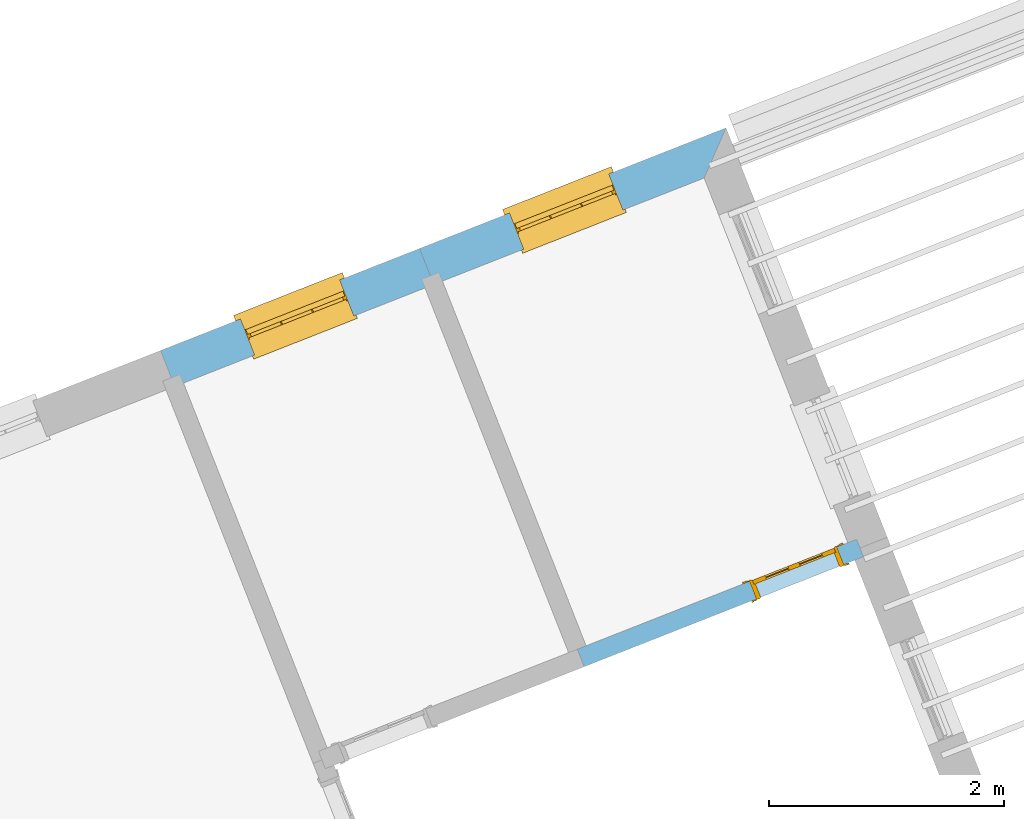
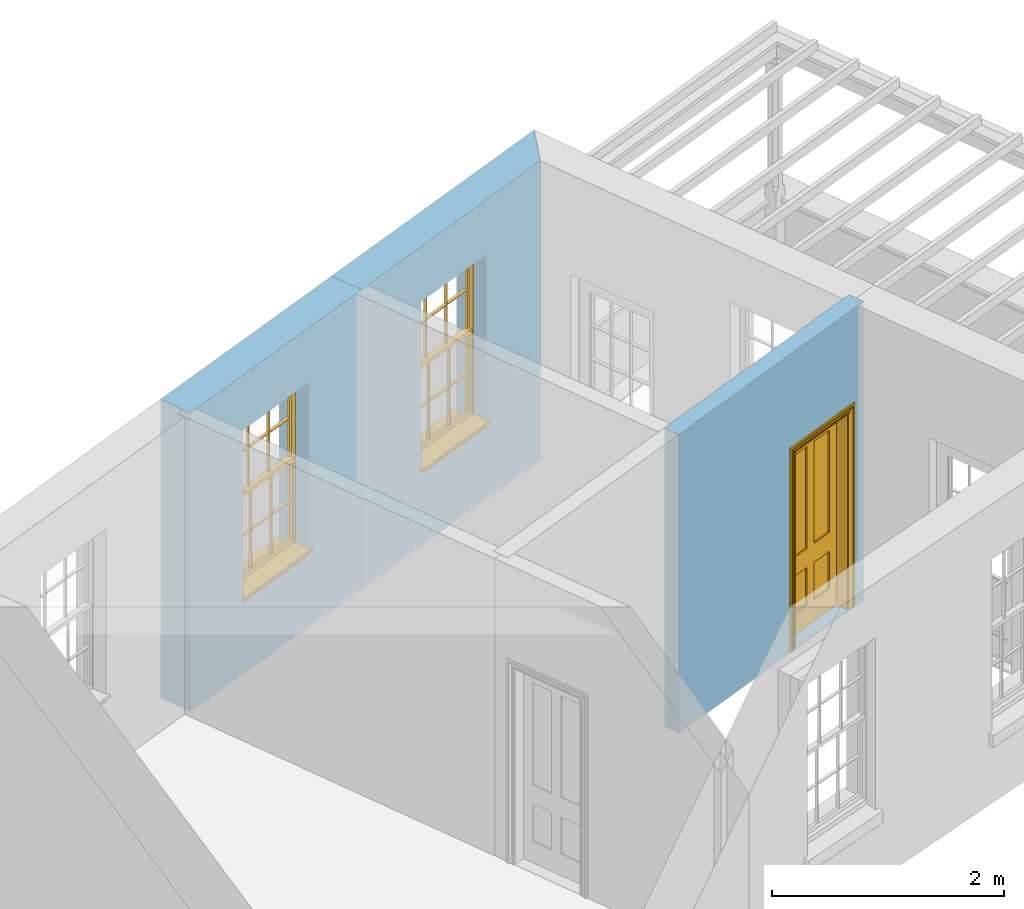
# One storey, part 4 of 8: 2 windows, 1 door, 3 openings, plus 3 elements that do not belong to this part.
"""IFC2X3 building model written with IfcOpenShell, lengths in metres."""

from ifc_helpers import new_model, si_unit, frame, origin, place, context, subcontext, project, spatial, polyline, outline, extrude, faceted_brep, material, layer, layer_set, layer_usage, element, fill, save


model = new_model("IFC2X3")

# Units and contexts
model_context = context("Model", 3, world=origin())
body_context = subcontext(model_context, "Body", "Model", "MODEL_VIEW")
ifc_project = project(units=[si_unit("PLANEANGLEUNIT", "RADIAN"), si_unit("MASSUNIT", "GRAM", prefix="KILO"), si_unit("FORCEUNIT", "NEWTON", prefix="KILO"), si_unit("LENGTHUNIT", "METRE")], contexts=[model_context])

# Site, building, storey
site_placement = place(None, origin())
site = spatial("IfcSite", under=ifc_project, at=site_placement, CompositionType="ELEMENT")
building_placement = place(None, origin())
building = spatial("IfcBuilding", under=site, at=building_placement, Name="Building plot-4", CompositionType="ELEMENT")
storey_placement = place(None, frame((0.0, 0.0, 9.45)))
storey = spatial("IfcBuildingStorey", under=building, at=storey_placement, Name="Floor 2", CompositionType="ELEMENT", Elevation=9.45)

# Wall, opening, window
ifc_material_1 = material(Name="Masonry")
ifc_layer_1 = layer(ifc_material_1, 0.33, ventilated=False)
ifc_layer_set_1 = layer_set([ifc_layer_1], Name="My Wall")
ifc_layer_usage_1 = layer_usage(ifc_layer_set_1, "AXIS2", "NEGATIVE", 0.08)
wall_1_placement = place(storey_placement, origin())
wall_1 = element("IfcWallStandardCase", 1, at=wall_1_placement, inside=storey, material=ifc_layer_usage_1, Name="exterior", context=body_context, shape_type="SweptSolid", body=[
    extrude(outline(polyline([(51.9622563685918, 53.743916100977), (52.148382249517, 54.1718847405405), (49.5373999145512, 53.1436274453256), (49.6583212938703, 52.8365801850812), (51.9622563685918, 53.743916100977)])), origin(), (0.0, 0.0, 1.0), 3.15),
])
opening_1_placement = place(storey_placement, frame((0.0, 0.0, 0.75)))
opening_1 = element("IfcOpeningElement", 2, at=opening_1_placement, cuts=wall_1, Name="Opening", ObjectType="Opening", context=body_context, shape_type="SweptSolid", body=[
    extrude(outline(polyline([(51.1499383422784, 53.7786774722522), (50.3032322609986, 53.4452276080691), (50.4241536403177, 53.1381803478247), (51.2708597215976, 53.4716302120078), (51.1499383422784, 53.7786774722522)])), origin(), (0.0, 0.0, 1.0), 1.82),
])
window_1_placement = place(storey_placement, frame((51.2415454478232, 53.546065911461, 0.75), z_axis=(0.0, 0.0, 1.0), x_axis=(-0.846706081279841, -0.333449864183102, 0.0)))
window_1 = element("IfcWindow", 3, at=window_1_placement, inside=storey, Name="bedroom outside window", OverallHeight=1.82, OverallWidth=0.91, context=body_context, shape_type="Brep", held_by="IfcProductRepresentation", body=[
    faceted_brep([(0.033125, -0.105, 0.975209), (0.01, -0.105, 0.975209), (0.033125, -0.105, 1.376042), (0.876875, -0.105, 0.975209), (0.876875, -0.105, 1.376042), (0.9, -0.105, 0.975209), (0.876875, -0.105, 1.386042), (0.876875, -0.105, 1.786875), (0.9, -0.105, 1.81), (0.033125, -0.105, 1.786875), (0.033125, -0.105, 1.386042), (0.01, -0.105, 1.81), (0.876875, -0.135, 1.376042), (0.876875, -0.135, 0.975209), (0.9, -0.135, 0.937083), (0.033125, -0.135, 1.786875), (0.01, -0.135, 1.81), (0.033125, -0.135, 1.386042), (0.01, -0.135, 0.937083), (0.033125, -0.135, 0.975209), (0.033125, -0.135, 1.376042), (0.876875, -0.135, 1.786875), (0.876875, -0.135, 1.386042), (0.9, -0.135, 1.81), (0.033125, -0.105, 0.937083), (0.01, -0.105, 0.937083), (0.033125, -0.105, 0.53625), (0.876875, -0.105, 0.937083), (0.876875, -0.105, 0.53625), (0.9, -0.105, 0.937083), (0.876875, -0.105, 0.52625), (0.876875, -0.105, 0.125417), (0.9, -0.105, 0.077167), (0.033125, -0.105, 0.125417), (0.033125, -0.105, 0.52625), (0.01, -0.105, 0.077167), (-0.0425, -0.25, 0.01), (-0.0425, -0.3, 0.001667), (0.0, -0.25, 0.01), (0.9525, -0.25, 0.01), (0.91, -0.25, 0.01), (0.9525, -0.3, 0.001667), (-0.02, 0.08, 0.077167), (0.0, 0.08, 0.077167), (-0.02, 0.11, 0.077167), (0.0, -0.06, 0.077167), (0.01, -0.06, 0.077167), (0.91, -0.06, 0.077167), (0.91, 0.08, 0.077167), (0.9, -0.06, 0.077167), (0.93, 0.08, 0.077167), (0.93, 0.11, 0.077167), (0.01, -0.075, 0.975209), (0.9, -0.075, 0.975209), (0.876875, -0.075, 0.125417), (0.876875, -0.075, 0.52625), (0.9, -0.075, 0.077167), (0.876875, -0.075, 0.53625), (0.876875, -0.075, 0.937083), (0.033125, -0.075, 0.125417), (0.01, -0.075, 0.077167), (0.033125, -0.075, 0.52625), (0.033125, -0.075, 0.937083), (0.033125, -0.075, 0.53625), (-0.02, 0.08, 0.052167), (-0.02, 0.11, 0.052167), (0.93, 0.11, 0.052167), (0.93, 0.08, 0.052167), (0.91, 0.08, 0.052167), (0.0, 0.08, 0.052167), (0.91, -0.15, 0.026667), (0.0, -0.15, 0.026667), (-0.0425, -0.3, -0.123333), (0.9525, -0.3, -0.123333), (-0.0425, -0.25, -0.123333), (0.9525, -0.25, -0.123333), (0.01, -0.06, 1.81), (0.9, -0.06, 1.81), (0.0, -0.06, 1.82), (0.91, -0.06, 1.82), (0.01, -0.15, 0.077167), (0.9, -0.15, 0.077167), (0.592292, -0.105, 0.125417), (0.592292, -0.075, 0.125417), (0.317708, -0.075, 0.125417), (0.317708, -0.105, 0.125417), (0.592292, -0.105, 0.53625), (0.317708, -0.105, 0.53625), (0.317708, -0.105, 0.52625), (0.592292, -0.105, 0.52625), (0.592292, -0.075, 0.53625), (0.317708, -0.075, 0.53625), (0.592292, -0.135, 1.386042), (0.592292, -0.105, 1.386042), (0.317708, -0.105, 1.386042), (0.317708, -0.135, 1.386042), (0.317708, -0.135, 1.376042), (0.592292, -0.135, 1.376042), (0.317708, -0.105, 1.376042), (0.592292, -0.105, 1.376042), (0.602292, -0.135, 1.376042), (0.592292, -0.135, 0.975209), (0.602292, -0.135, 0.975209), (0.602292, -0.105, 0.975209), (0.592292, -0.105, 0.975209), (0.602292, -0.105, 1.376042), (0.602292, -0.075, 0.53625), (0.602292, -0.105, 0.53625), (0.317708, -0.075, 0.52625), (0.307708, -0.075, 0.125417), (0.307708, -0.075, 0.52625), (0.602292, -0.075, 0.52625), (0.602292, -0.075, 0.125417), (0.592292, -0.075, 0.52625), (0.307708, -0.075, 0.53625), (0.317708, -0.075, 0.937083), (0.307708, -0.075, 0.937083), (0.602292, -0.075, 0.937083), (0.592292, -0.075, 0.937083), (0.307708, -0.105, 0.52625), (0.307708, -0.105, 0.125417), (0.307708, -0.105, 0.53625), (0.307708, -0.105, 0.937083), (0.592292, -0.105, 0.937083), (0.317708, -0.105, 0.937083), (0.602292, -0.105, 0.937083), (0.602292, -0.105, 0.52625), (0.602292, -0.105, 0.125417), (0.307708, -0.135, 1.386042), (0.307708, -0.135, 1.376042), (0.307708, -0.135, 0.975209), (0.317708, -0.135, 0.975209), (0.317708, -0.135, 1.786875), (0.307708, -0.135, 1.786875), (0.602292, -0.135, 1.786875), (0.592292, -0.135, 1.786875), (0.602292, -0.135, 1.386042), (0.602292, -0.105, 1.386042), (0.307708, -0.105, 1.386042), (0.307708, -0.105, 1.786875), (0.317708, -0.105, 1.786875), (0.592292, -0.105, 1.786875), (0.602292, -0.105, 1.786875), (0.307708, -0.105, 1.376042), (0.317708, -0.105, 0.975209), (0.307708, -0.105, 0.975209), (0.91, -0.15, 1.82), (0.9, -0.15, 1.81), (0.01, -0.15, 1.81), (0.0, -0.15, 1.82), (0.91, -0.25, 0.0), (0.0, -0.25, 0.0), (0.91, 0.08, 0.0), (0.0, 0.08, 0.0)], [[[0, 1, 2]], [[3, 4, 5]], [[6, 7, 8]], [[9, 10, 11]], [[12, 13, 14]], [[15, 16, 17]], [[18, 19, 20]], [[21, 22, 23]], [[24, 25, 26]], [[27, 28, 29]], [[30, 31, 32]], [[33, 34, 35]], [[14, 27, 29]], [[25, 24, 18]], [[36, 37, 38]], [[39, 40, 41]], [[42, 43, 44]], [[45, 46, 43]], [[47, 48, 49]], [[50, 51, 48]], [[1, 0, 52]], [[5, 53, 3]], [[54, 55, 56]], [[57, 58, 53]], [[59, 60, 61]], [[62, 63, 52]], [[48, 43, 46, 49]], [[51, 44, 43, 48]], [[64, 42, 44, 65]], [[65, 44, 51, 66]], [[66, 51, 50, 67]], [[65, 66, 68, 69]], [[60, 56, 49, 46]], [[70, 71, 38, 40]], [[37, 41, 40, 38]], [[37, 72, 73, 41]], [[74, 75, 73, 72]], [[8, 11, 76, 77]], [[76, 78, 79, 77]], [[32, 35, 80, 81]], [[81, 80, 71, 70]], [[82, 83, 84, 85]], [[86, 87, 88, 89]], [[86, 90, 91, 87]], [[92, 93, 94, 95]], [[92, 95, 96, 97]], [[96, 98, 99, 97]], [[100, 97, 101, 102]], [[103, 104, 99, 105]], [[97, 99, 104, 101]], [[102, 103, 105, 100]], [[28, 57, 106, 107]], [[108, 84, 109, 110]], [[111, 112, 83, 113]], [[114, 110, 61, 63]], [[90, 113, 108, 91]], [[115, 91, 114, 116]], [[117, 106, 90, 118]], [[111, 106, 57, 55]], [[119, 110, 109, 120]], [[34, 61, 110, 119]], [[89, 113, 83, 82]], [[88, 108, 113, 89]], [[85, 84, 108, 88]], [[121, 114, 63, 26]], [[122, 116, 114, 121]], [[123, 118, 90, 86]], [[87, 91, 115, 124]], [[107, 106, 117, 125]], [[126, 111, 55, 30]], [[127, 112, 111, 126]], [[126, 30, 28, 107]], [[88, 119, 120, 85]], [[126, 89, 82, 127]], [[125, 123, 86, 107]], [[121, 26, 34, 119]], [[124, 122, 121, 87]], [[128, 17, 20, 129]], [[96, 129, 130, 131]], [[132, 133, 128, 95]], [[134, 135, 92, 136]], [[100, 12, 22, 136]], [[137, 6, 4, 105]], [[94, 138, 139, 140]], [[137, 93, 141, 142]], [[99, 98, 94, 93]], [[143, 2, 10, 138]], [[144, 145, 143, 98]], [[129, 143, 145, 130]], [[20, 2, 143, 129]], [[131, 144, 98, 96]], [[128, 138, 10, 17]], [[133, 139, 138, 128]], [[135, 141, 93, 92]], [[95, 94, 140, 132]], [[22, 6, 137, 136]], [[136, 137, 142, 134]], [[100, 105, 4, 12]], [[107, 86, 89, 126]], [[106, 111, 113, 90]], [[91, 108, 110, 114]], [[87, 121, 119, 88]], [[97, 100, 136, 92]], [[129, 96, 95, 128]], [[98, 143, 138, 94]], [[105, 99, 93, 137]], [[131, 101, 104, 144]], [[124, 115, 118, 123]], [[132, 140, 141, 135]], [[120, 109, 59, 33]], [[15, 9, 139, 133]], [[134, 142, 7, 21]], [[31, 54, 112, 127]], [[36, 74, 72, 37]], [[39, 41, 73, 75]], [[18, 14, 101, 131]], [[23, 16, 132, 135]], [[83, 56, 60, 84]], [[52, 53, 118, 115]], [[53, 52, 144, 104]], [[11, 8, 141, 140]], [[14, 18, 124, 123]], [[2, 1, 11, 10]], [[8, 5, 4, 6]], [[57, 53, 56, 55]], [[60, 52, 63, 61]], [[26, 25, 35, 34]], [[32, 29, 28, 30]], [[14, 23, 22, 12]], [[18, 20, 17, 16]], [[19, 0, 2, 20]], [[17, 10, 9, 15]], [[12, 4, 3, 13]], [[21, 7, 6, 22]], [[27, 58, 57, 28]], [[30, 55, 54, 31]], [[33, 59, 61, 34]], [[26, 63, 62, 24]], [[5, 8, 77, 53]], [[76, 11, 1, 52]], [[46, 45, 78, 76]], [[49, 77, 79, 47]], [[70, 146, 147, 81]], [[71, 80, 148, 149]], [[19, 130, 145, 0]], [[102, 13, 3, 103]], [[116, 122, 24, 62]], [[29, 32, 81, 14]], [[80, 35, 25, 18]], [[60, 46, 76, 52]], [[77, 49, 56, 53]], [[23, 14, 81, 147]], [[16, 148, 80, 18]], [[35, 85, 120]], [[120, 33, 35]], [[127, 82, 32]], [[32, 31, 127]], [[32, 82, 85, 35]], [[102, 101, 14]], [[14, 13, 102]], [[18, 131, 130]], [[130, 19, 18]], [[134, 21, 23]], [[23, 135, 134]], [[16, 15, 133]], [[133, 132, 16]], [[11, 140, 139]], [[139, 9, 11]], [[142, 141, 8]], [[8, 7, 142]], [[23, 147, 148, 16]], [[146, 149, 148, 147]], [[52, 115, 116]], [[116, 62, 52]], [[118, 53, 117]], [[58, 117, 53]], [[27, 125, 117, 58]], [[56, 83, 112]], [[112, 54, 56]], [[109, 84, 60]], [[60, 59, 109]], [[125, 27, 14]], [[14, 123, 125]], [[122, 124, 18]], [[18, 24, 122]], [[145, 144, 52]], [[52, 0, 145]], [[103, 3, 53]], [[53, 104, 103]], [[79, 78, 149, 146]], [[78, 45, 71, 149]], [[146, 70, 47, 79]], [[150, 75, 74, 151]], [[68, 66, 67]], [[48, 68, 67, 50]], [[69, 64, 65]], [[42, 64, 69, 43]], [[69, 68, 152, 153]], [[70, 68, 48, 47]], [[150, 152, 68, 70]], [[43, 69, 71, 45]], [[69, 153, 151, 71]], [[152, 150, 151, 153]], [[38, 151, 74, 36]], [[71, 151, 38]], [[39, 75, 150, 40]], [[40, 150, 70]]]),
])
fill(opening_1, window_1)

wall_2_placement = place(storey_placement, origin())
wall_2 = element("IfcWallStandardCase", 4, at=wall_2_placement, inside=storey, material=ifc_layer_usage_1, Name="exterior", context=body_context, shape_type="SweptSolid", body=[
    extrude(outline(polyline([(49.6583212938703, 52.8365801850812), (49.5373999145512, 53.1436274453256), (47.3314871355126, 52.2748946786277), (47.4524085148317, 51.9678474183833), (49.6583212938703, 52.8365801850812)])), origin(), (0.0, 0.0, 1.0), 3.15),
])
opening_2_placement = place(storey_placement, frame((0.0, 0.0, 0.75)))
opening_2 = element("IfcOpeningElement", 5, at=opening_2_placement, cuts=wall_2, Name="Opening", ObjectType="Opening", context=body_context, shape_type="SweptSolid", body=[
    extrude(outline(polyline([(48.8577965656718, 52.8759859940682), (48.011090484392, 52.5425361298851), (48.1320118637111, 52.2354888696407), (48.978717944991, 52.5689387338238), (48.8577965656718, 52.8759859940682)])), origin(), (0.0, 0.0, 1.0), 1.82),
])
window_2_placement = place(storey_placement, frame((48.9494036712166, 52.643374433277, 0.75), z_axis=(0.0, 0.0, 1.0), x_axis=(-0.846706081279848, -0.333449864183095, 0.0)))
window_2 = element("IfcWindow", 6, at=window_2_placement, inside=storey, Name="toilet outside window", OverallHeight=1.82, OverallWidth=0.91, context=body_context, shape_type="Brep", held_by="IfcProductRepresentation", body=[
    faceted_brep([(0.033125, -0.105, 0.975209), (0.01, -0.105, 0.975209), (0.033125, -0.105, 1.376042), (0.876875, -0.105, 0.975209), (0.876875, -0.105, 1.376042), (0.9, -0.105, 0.975209), (0.876875, -0.105, 1.386042), (0.876875, -0.105, 1.786875), (0.9, -0.105, 1.81), (0.033125, -0.105, 1.786875), (0.033125, -0.105, 1.386042), (0.01, -0.105, 1.81), (0.876875, -0.135, 1.376042), (0.876875, -0.135, 0.975209), (0.9, -0.135, 0.937083), (0.033125, -0.135, 1.786875), (0.01, -0.135, 1.81), (0.033125, -0.135, 1.386042), (0.01, -0.135, 0.937083), (0.033125, -0.135, 0.975209), (0.033125, -0.135, 1.376042), (0.876875, -0.135, 1.786875), (0.876875, -0.135, 1.386042), (0.9, -0.135, 1.81), (0.033125, -0.105, 0.937083), (0.01, -0.105, 0.937083), (0.033125, -0.105, 0.53625), (0.876875, -0.105, 0.937083), (0.876875, -0.105, 0.53625), (0.9, -0.105, 0.937083), (0.876875, -0.105, 0.52625), (0.876875, -0.105, 0.125417), (0.9, -0.105, 0.077167), (0.033125, -0.105, 0.125417), (0.033125, -0.105, 0.52625), (0.01, -0.105, 0.077167), (-0.0425, -0.25, 0.01), (-0.0425, -0.3, 0.001667), (0.0, -0.25, 0.01), (0.9525, -0.25, 0.01), (0.91, -0.25, 0.01), (0.9525, -0.3, 0.001667), (-0.02, 0.08, 0.077167), (0.0, 0.08, 0.077167), (-0.02, 0.11, 0.077167), (0.0, -0.06, 0.077167), (0.01, -0.06, 0.077167), (0.91, -0.06, 0.077167), (0.91, 0.08, 0.077167), (0.9, -0.06, 0.077167), (0.93, 0.08, 0.077167), (0.93, 0.11, 0.077167), (0.01, -0.075, 0.975209), (0.9, -0.075, 0.975209), (0.876875, -0.075, 0.125417), (0.876875, -0.075, 0.52625), (0.9, -0.075, 0.077167), (0.876875, -0.075, 0.53625), (0.876875, -0.075, 0.937083), (0.033125, -0.075, 0.125417), (0.01, -0.075, 0.077167), (0.033125, -0.075, 0.52625), (0.033125, -0.075, 0.937083), (0.033125, -0.075, 0.53625), (-0.02, 0.08, 0.052167), (-0.02, 0.11, 0.052167), (0.93, 0.11, 0.052167), (0.93, 0.08, 0.052167), (0.91, 0.08, 0.052167), (0.0, 0.08, 0.052167), (0.91, -0.15, 0.026667), (0.0, -0.15, 0.026667), (-0.0425, -0.3, -0.123333), (0.9525, -0.3, -0.123333), (-0.0425, -0.25, -0.123333), (0.9525, -0.25, -0.123333), (0.01, -0.06, 1.81), (0.9, -0.06, 1.81), (0.0, -0.06, 1.82), (0.91, -0.06, 1.82), (0.01, -0.15, 0.077167), (0.9, -0.15, 0.077167), (0.592292, -0.105, 0.125417), (0.592292, -0.075, 0.125417), (0.317708, -0.075, 0.125417), (0.317708, -0.105, 0.125417), (0.592292, -0.105, 0.53625), (0.317708, -0.105, 0.53625), (0.317708, -0.105, 0.52625), (0.592292, -0.105, 0.52625), (0.592292, -0.075, 0.53625), (0.317708, -0.075, 0.53625), (0.592292, -0.135, 1.386042), (0.592292, -0.105, 1.386042), (0.317708, -0.105, 1.386042), (0.317708, -0.135, 1.386042), (0.317708, -0.135, 1.376042), (0.592292, -0.135, 1.376042), (0.317708, -0.105, 1.376042), (0.592292, -0.105, 1.376042), (0.602292, -0.135, 1.376042), (0.592292, -0.135, 0.975209), (0.602292, -0.135, 0.975209), (0.602292, -0.105, 0.975209), (0.592292, -0.105, 0.975209), (0.602292, -0.105, 1.376042), (0.602292, -0.075, 0.53625), (0.602292, -0.105, 0.53625), (0.317708, -0.075, 0.52625), (0.307708, -0.075, 0.125417), (0.307708, -0.075, 0.52625), (0.602292, -0.075, 0.52625), (0.602292, -0.075, 0.125417), (0.592292, -0.075, 0.52625), (0.307708, -0.075, 0.53625), (0.317708, -0.075, 0.937083), (0.307708, -0.075, 0.937083), (0.602292, -0.075, 0.937083), (0.592292, -0.075, 0.937083), (0.307708, -0.105, 0.52625), (0.307708, -0.105, 0.125417), (0.307708, -0.105, 0.53625), (0.307708, -0.105, 0.937083), (0.592292, -0.105, 0.937083), (0.317708, -0.105, 0.937083), (0.602292, -0.105, 0.937083), (0.602292, -0.105, 0.52625), (0.602292, -0.105, 0.125417), (0.307708, -0.135, 1.386042), (0.307708, -0.135, 1.376042), (0.307708, -0.135, 0.975209), (0.317708, -0.135, 0.975209), (0.317708, -0.135, 1.786875), (0.307708, -0.135, 1.786875), (0.602292, -0.135, 1.786875), (0.592292, -0.135, 1.786875), (0.602292, -0.135, 1.386042), (0.602292, -0.105, 1.386042), (0.307708, -0.105, 1.386042), (0.307708, -0.105, 1.786875), (0.317708, -0.105, 1.786875), (0.592292, -0.105, 1.786875), (0.602292, -0.105, 1.786875), (0.307708, -0.105, 1.376042), (0.317708, -0.105, 0.975209), (0.307708, -0.105, 0.975209), (0.91, -0.15, 1.82), (0.9, -0.15, 1.81), (0.01, -0.15, 1.81), (0.0, -0.15, 1.82), (0.91, -0.25, 0.0), (0.0, -0.25, 0.0), (0.91, 0.08, 0.0), (0.0, 0.08, 0.0)], [[[0, 1, 2]], [[3, 4, 5]], [[6, 7, 8]], [[9, 10, 11]], [[12, 13, 14]], [[15, 16, 17]], [[18, 19, 20]], [[21, 22, 23]], [[24, 25, 26]], [[27, 28, 29]], [[30, 31, 32]], [[33, 34, 35]], [[14, 27, 29]], [[25, 24, 18]], [[36, 37, 38]], [[39, 40, 41]], [[42, 43, 44]], [[45, 46, 43]], [[47, 48, 49]], [[50, 51, 48]], [[1, 0, 52]], [[5, 53, 3]], [[54, 55, 56]], [[57, 58, 53]], [[59, 60, 61]], [[62, 63, 52]], [[48, 43, 46, 49]], [[51, 44, 43, 48]], [[64, 42, 44, 65]], [[65, 44, 51, 66]], [[66, 51, 50, 67]], [[65, 66, 68, 69]], [[60, 56, 49, 46]], [[70, 71, 38, 40]], [[37, 41, 40, 38]], [[37, 72, 73, 41]], [[74, 75, 73, 72]], [[8, 11, 76, 77]], [[76, 78, 79, 77]], [[32, 35, 80, 81]], [[81, 80, 71, 70]], [[82, 83, 84, 85]], [[86, 87, 88, 89]], [[86, 90, 91, 87]], [[92, 93, 94, 95]], [[92, 95, 96, 97]], [[96, 98, 99, 97]], [[100, 97, 101, 102]], [[103, 104, 99, 105]], [[97, 99, 104, 101]], [[102, 103, 105, 100]], [[28, 57, 106, 107]], [[108, 84, 109, 110]], [[111, 112, 83, 113]], [[114, 110, 61, 63]], [[90, 113, 108, 91]], [[115, 91, 114, 116]], [[117, 106, 90, 118]], [[111, 106, 57, 55]], [[119, 110, 109, 120]], [[34, 61, 110, 119]], [[89, 113, 83, 82]], [[88, 108, 113, 89]], [[85, 84, 108, 88]], [[121, 114, 63, 26]], [[122, 116, 114, 121]], [[123, 118, 90, 86]], [[87, 91, 115, 124]], [[107, 106, 117, 125]], [[126, 111, 55, 30]], [[127, 112, 111, 126]], [[126, 30, 28, 107]], [[88, 119, 120, 85]], [[126, 89, 82, 127]], [[125, 123, 86, 107]], [[121, 26, 34, 119]], [[124, 122, 121, 87]], [[128, 17, 20, 129]], [[96, 129, 130, 131]], [[132, 133, 128, 95]], [[134, 135, 92, 136]], [[100, 12, 22, 136]], [[137, 6, 4, 105]], [[94, 138, 139, 140]], [[137, 93, 141, 142]], [[99, 98, 94, 93]], [[143, 2, 10, 138]], [[144, 145, 143, 98]], [[129, 143, 145, 130]], [[20, 2, 143, 129]], [[131, 144, 98, 96]], [[128, 138, 10, 17]], [[133, 139, 138, 128]], [[135, 141, 93, 92]], [[95, 94, 140, 132]], [[22, 6, 137, 136]], [[136, 137, 142, 134]], [[100, 105, 4, 12]], [[107, 86, 89, 126]], [[106, 111, 113, 90]], [[91, 108, 110, 114]], [[87, 121, 119, 88]], [[97, 100, 136, 92]], [[129, 96, 95, 128]], [[98, 143, 138, 94]], [[105, 99, 93, 137]], [[131, 101, 104, 144]], [[124, 115, 118, 123]], [[132, 140, 141, 135]], [[120, 109, 59, 33]], [[15, 9, 139, 133]], [[134, 142, 7, 21]], [[31, 54, 112, 127]], [[36, 74, 72, 37]], [[39, 41, 73, 75]], [[18, 14, 101, 131]], [[23, 16, 132, 135]], [[83, 56, 60, 84]], [[52, 53, 118, 115]], [[53, 52, 144, 104]], [[11, 8, 141, 140]], [[14, 18, 124, 123]], [[2, 1, 11, 10]], [[8, 5, 4, 6]], [[57, 53, 56, 55]], [[60, 52, 63, 61]], [[26, 25, 35, 34]], [[32, 29, 28, 30]], [[14, 23, 22, 12]], [[18, 20, 17, 16]], [[19, 0, 2, 20]], [[17, 10, 9, 15]], [[12, 4, 3, 13]], [[21, 7, 6, 22]], [[27, 58, 57, 28]], [[30, 55, 54, 31]], [[33, 59, 61, 34]], [[26, 63, 62, 24]], [[5, 8, 77, 53]], [[76, 11, 1, 52]], [[46, 45, 78, 76]], [[49, 77, 79, 47]], [[70, 146, 147, 81]], [[71, 80, 148, 149]], [[19, 130, 145, 0]], [[102, 13, 3, 103]], [[116, 122, 24, 62]], [[29, 32, 81, 14]], [[80, 35, 25, 18]], [[60, 46, 76, 52]], [[77, 49, 56, 53]], [[23, 14, 81, 147]], [[16, 148, 80, 18]], [[35, 85, 120]], [[120, 33, 35]], [[127, 82, 32]], [[32, 31, 127]], [[32, 82, 85, 35]], [[102, 101, 14]], [[14, 13, 102]], [[18, 131, 130]], [[130, 19, 18]], [[134, 21, 23]], [[23, 135, 134]], [[16, 15, 133]], [[133, 132, 16]], [[11, 140, 139]], [[139, 9, 11]], [[142, 141, 8]], [[8, 7, 142]], [[23, 147, 148, 16]], [[146, 149, 148, 147]], [[52, 115, 116]], [[116, 62, 52]], [[118, 53, 117]], [[58, 117, 53]], [[27, 125, 117, 58]], [[56, 83, 112]], [[112, 54, 56]], [[109, 84, 60]], [[60, 59, 109]], [[125, 27, 14]], [[14, 123, 125]], [[122, 124, 18]], [[18, 24, 122]], [[145, 144, 52]], [[52, 0, 145]], [[103, 3, 53]], [[53, 104, 103]], [[79, 78, 149, 146]], [[78, 45, 71, 149]], [[146, 70, 47, 79]], [[150, 75, 74, 151]], [[68, 66, 67]], [[48, 68, 67, 50]], [[69, 64, 65]], [[42, 64, 69, 43]], [[69, 68, 152, 153]], [[70, 68, 48, 47]], [[150, 152, 68, 70]], [[43, 69, 71, 45]], [[69, 153, 151, 71]], [[152, 150, 151, 153]], [[38, 151, 74, 36]], [[71, 151, 38]], [[39, 75, 150, 40]], [[40, 150, 70]]]),
])
fill(opening_2, window_2)

# Wall, opening, door
ifc_material_2 = material(Name="Masonry")
ifc_layer_2 = layer(ifc_material_2, 0.16, ventilated=False)
ifc_layer_set_2 = layer_set([ifc_layer_2], Name="My Wall")
ifc_layer_usage_2 = layer_usage(ifc_layer_set_2, "AXIS2", "NEGATIVE", 0.08)
wall_3_placement = place(storey_placement, origin())
wall_3 = element("IfcWallStandardCase", 7, at=wall_3_placement, inside=storey, material=ifc_layer_usage_2, Name="interior", context=body_context, shape_type="SweptSolid", body=[
    extrude(outline(polyline([(50.8818764388166, 49.7296915841659), (50.9405049863652, 49.5808201852595), (53.3188757605398, 50.5174703749296), (53.2602472129912, 50.666341773836), (50.8818764388166, 49.7296915841659)])), origin(), (0.0, 0.0, 1.0), 3.15),
])
opening_3_placement = place(storey_placement, frame((0.0, 0.0, 0.0199999999999996)))
opening_3 = element("IfcOpeningElement", 8, at=opening_3_placement, cuts=wall_3, Name="Opening", ObjectType="Opening", context=body_context, shape_type="SweptSolid", body=[
    extrude(outline(polyline([(52.4070384422385, 50.158370521194), (53.1513954367702, 50.4515132589374), (53.0927668892215, 50.6003846578437), (52.3484098946898, 50.3072419201003), (52.4070384422385, 50.158370521194)])), origin(), (0.0, 0.0, 1.0), 2.1),
])
door_placement = place(storey_placement, frame((52.3777241684641, 50.2328062206471, 0.0199999999999996), z_axis=(0.0, 0.0, 1.0), x_axis=(0.744356994531735, 0.293142737743388, 0.0)))
door = element("IfcDoor", 9, at=door_placement, inside=storey, Name="bedroom inside door", OverallHeight=2.1, OverallWidth=0.8, context=body_context, shape_type="Brep", held_by="IfcProductRepresentation", body=[
    faceted_brep([(0.773, 0.08, 1.895), (0.66, 0.08, 1.895), (0.66, 0.08, 2.073), (0.773, 0.08, 2.073), (0.773, 0.08, 0.82), (0.66, 0.08, 0.82), (0.45, 0.08, 1.895), (0.45, 0.08, 2.073), (0.773, 0.08, 0.62), (0.66, 0.08, 0.62), (0.66, 0.065, 0.82), (0.66, 0.065, 1.895), (0.45, 0.065, 1.895), (0.35, 0.08, 1.895), (0.35, 0.08, 2.073), (0.773, 0.08, 0.225), (0.66, 0.08, 0.225), (0.45, 0.08, 0.62), (0.45, 0.08, 0.82), (0.45, 0.065, 0.82), (0.35, 0.08, 0.82), (0.14, 0.08, 2.073), (0.14, 0.08, 1.895), (0.773, 0.08, 0.0), (0.66, 0.08, 0.0), (0.66, 0.065, 0.225), (0.66, 0.065, 0.62), (0.45, 0.065, 0.62), (0.35, 0.08, 0.62), (0.35, 0.065, 0.82), (0.35, 0.065, 1.895), (0.14, 0.065, 1.895), (0.027, 0.08, 2.073), (0.027, 0.08, 1.895), (0.773, 0.042, 0.0), (0.66, 0.042, 0.0), (0.45, 0.08, 0.0), (0.45, 0.08, 0.225), (0.45, 0.065, 0.225), (0.35, 0.08, 0.225), (0.14, 0.08, 0.82), (0.14, 0.08, 0.62), (0.14, 0.065, 0.82), (0.027, 0.08, 0.82), (0.773, 0.042, 0.225), (0.66, 0.042, 0.225), (0.45, 0.042, 0.0), (0.35, 0.08, 0.0), (0.35, 0.065, 0.225), (0.35, 0.065, 0.62), (0.14, 0.065, 0.62), (0.027, 0.08, 0.62), (0.773, 0.042, 0.62), (0.66, 0.042, 0.62), (0.45, 0.042, 0.225), (0.35, 0.042, 0.0), (0.14, 0.08, 0.225), (0.14, 0.08, 0.0), (0.14, 0.065, 0.225), (0.027, 0.08, 0.225), (0.773, 0.042, 0.82), (0.66, 0.042, 0.82), (0.66, 0.057, 0.62), (0.66, 0.057, 0.225), (0.45, 0.057, 0.225), (0.35, 0.042, 0.225), (0.14, 0.042, 0.0), (0.027, 0.08, 0.0), (0.773, 0.042, 1.895), (0.66, 0.042, 1.895), (0.45, 0.042, 0.62), (0.45, 0.042, 0.82), (0.45, 0.057, 0.62), (0.35, 0.042, 0.62), (0.14, 0.042, 0.225), (0.027, 0.042, 0.0), (0.773, 0.042, 2.073), (0.66, 0.042, 2.073), (0.66, 0.057, 1.895), (0.66, 0.057, 0.82), (0.45, 0.057, 0.82), (0.35, 0.042, 0.82), (0.35, 0.057, 0.62), (0.35, 0.057, 0.225), (0.14, 0.057, 0.225), (0.027, 0.042, 0.225), (0.45, 0.042, 1.895), (0.45, 0.042, 2.073), (0.45, 0.057, 1.895), (0.35, 0.042, 1.895), (0.14, 0.042, 0.82), (0.14, 0.042, 0.62), (0.14, 0.057, 0.62), (0.027, 0.042, 0.62), (0.35, 0.042, 2.073), (0.35, 0.057, 1.895), (0.35, 0.057, 0.82), (0.14, 0.057, 0.82), (0.027, 0.042, 0.82), (0.14, 0.042, 2.073), (0.14, 0.042, 1.895), (0.14, 0.057, 1.895), (0.027, 0.042, 1.895), (0.027, 0.042, 2.073), (0.02, 0.085, 0.0), (0.005, 0.09, 0.0), (0.005, 0.09, 2.095), (0.02, 0.085, 2.08), (0.02, 0.08, 0.0), (0.0, 0.085, 0.0), (0.0, 0.085, 2.1), (0.795, 0.09, 2.095), (0.78, 0.085, 2.08), (0.02, 0.08, 2.08), (0.0, 0.08, 0.0), (-0.032, 0.095, 0.0), (-0.032, 0.095, 2.132), (0.8, 0.085, 2.1), (0.795, 0.09, 0.0), (0.78, 0.085, 0.0), (0.78, 0.08, 2.08), (0.04, 0.04, 0.0), (0.025, 0.04, 0.0), (0.025, 0.04, 2.075), (0.04, 0.04, 2.06), (-0.04, 0.09, 0.0), (-0.04, 0.09, 2.14), (0.832, 0.095, 2.132), (0.8, 0.085, 0.0), (0.78, 0.08, 0.0), (0.8, 0.08, 0.0), (0.86, 0.08, 0.0), (0.86, 0.08, 2.16), (0.8, 0.08, 2.1), (-0.06, 0.08, 2.16), (0.0, 0.08, 2.1), (-0.06, 0.08, 0.0), (-0.04, 0.095, 0.0), (-0.04, 0.095, 2.14), (0.84, 0.09, 2.14), (0.832, 0.095, 0.0), (0.84, 0.09, 0.0), (0.86, 0.095, 0.0), (0.86, 0.095, 2.16), (-0.06, 0.095, 2.16), (-0.06, 0.095, 0.0), (0.84, 0.095, 0.0), (0.84, 0.095, 2.14), (-0.025, -0.095, 0.0), (-0.025, -0.09, 0.0), (-0.025, -0.09, 2.125), (-0.025, -0.095, 2.125), (-0.017, -0.095, 0.0), (-0.017, -0.095, 2.117), (0.825, -0.09, 2.125), (0.825, -0.095, 2.125), (0.825, -0.095, 0.0), (0.845, -0.095, 0.0), (-0.045, -0.095, 2.145), (-0.045, -0.095, 0.0), (0.845, -0.095, 2.145), (0.015, -0.085, 0.0), (0.015, -0.085, 2.085), (0.817, -0.095, 2.117), (0.825, -0.09, 0.0), (0.845, -0.08, 0.0), (0.845, -0.08, 2.145), (-0.045, -0.08, 2.145), (-0.045, -0.08, 0.0), (0.02, -0.09, 0.0), (0.02, -0.09, 2.08), (0.785, -0.085, 2.085), (0.817, -0.095, 0.0), (0.8, -0.08, 0.0), (0.8, -0.08, 2.1), (0.0, -0.08, 2.1), (0.0, -0.08, 0.0), (0.035, -0.085, 0.0), (0.035, -0.085, 2.065), (0.78, -0.09, 2.08), (0.785, -0.085, 0.0), (0.775, 0.04, 2.075), (0.76, 0.04, 2.06), (0.035, -0.08, 2.065), (0.035, -0.08, 0.0), (0.765, -0.085, 2.065), (0.78, -0.09, 0.0), (0.765, -0.08, 0.0), (0.765, -0.08, 2.065), (0.765, -0.085, 0.0), (0.04, -0.08, 2.06), (0.04, -0.08, 0.0), (0.76, -0.08, 2.06), (0.76, -0.08, 0.0), (0.76, 0.04, 0.0), (0.775, 0.04, 0.0), (0.025, 0.08, 0.0), (0.025, 0.08, 2.075), (0.775, 0.08, 0.0), (0.775, 0.08, 2.075)], [[[0, 1, 2, 3]], [[1, 0, 4, 5]], [[1, 6, 7, 2]], [[8, 9, 5, 4]], [[1, 5, 10, 11]], [[6, 1, 11, 12]], [[6, 13, 14, 7]], [[15, 16, 9, 8]], [[9, 17, 18, 5]], [[5, 18, 19, 10]], [[10, 19, 12, 11]], [[18, 6, 12, 19]], [[18, 20, 13, 6]], [[21, 14, 13, 22]], [[23, 24, 16, 15]], [[9, 16, 25, 26]], [[17, 9, 26, 27]], [[17, 28, 20, 18]], [[13, 20, 29, 30]], [[22, 13, 30, 31]], [[32, 21, 22, 33]], [[34, 35, 24, 23]], [[24, 36, 37, 16]], [[16, 37, 38, 25]], [[25, 38, 27, 26]], [[37, 17, 27, 38]], [[37, 39, 28, 17]], [[40, 20, 28, 41]], [[20, 40, 42, 29]], [[31, 30, 29, 42]], [[40, 22, 31, 42]], [[33, 22, 40, 43]], [[35, 34, 44, 45]], [[35, 46, 36, 24]], [[36, 47, 39, 37]], [[28, 39, 48, 49]], [[41, 28, 49, 50]], [[43, 40, 41, 51]], [[45, 44, 52, 53]], [[46, 35, 45, 54]], [[46, 55, 47, 36]], [[56, 39, 47, 57]], [[39, 56, 58, 48]], [[50, 49, 48, 58]], [[56, 41, 50, 58]], [[51, 41, 56, 59]], [[53, 52, 60, 61]], [[45, 53, 62, 63]], [[54, 45, 63, 64]], [[55, 46, 54, 65]], [[55, 66, 57, 47]], [[59, 56, 57, 67]], [[61, 60, 68, 69]], [[70, 53, 61, 71]], [[53, 70, 72, 62]], [[72, 64, 63, 62]], [[70, 54, 64, 72]], [[65, 54, 70, 73]], [[65, 74, 66, 55]], [[67, 57, 66, 75]], [[69, 68, 76, 77]], [[61, 69, 78, 79]], [[71, 61, 79, 80]], [[73, 70, 71, 81]], [[65, 73, 82, 83]], [[74, 65, 83, 84]], [[74, 85, 75, 66]], [[86, 69, 77, 87]], [[69, 86, 88, 78]], [[88, 80, 79, 78]], [[86, 71, 80, 88]], [[81, 71, 86, 89]], [[73, 81, 90, 91]], [[73, 91, 92, 82]], [[83, 82, 92, 84]], [[91, 74, 84, 92]], [[91, 93, 85, 74]], [[89, 86, 87, 94]], [[81, 89, 95, 96]], [[90, 81, 96, 97]], [[90, 98, 93, 91]], [[94, 99, 100, 89]], [[89, 100, 101, 95]], [[101, 97, 96, 95]], [[100, 90, 97, 101]], [[100, 102, 98, 90]], [[99, 103, 102, 100]], [[32, 103, 99, 21]], [[102, 103, 32, 33]], [[98, 102, 33, 43]], [[21, 99, 94, 14]], [[94, 87, 7, 14]], [[7, 87, 77, 2]], [[76, 3, 2, 77]], [[43, 51, 93, 98]], [[51, 59, 85, 93]], [[67, 75, 85, 59]], [[34, 23, 15, 44]], [[44, 15, 8, 52]], [[52, 8, 4, 60]], [[0, 68, 60, 4]], [[0, 3, 76, 68]], [[104, 105, 106, 107]], [[104, 108, 109, 105]], [[105, 109, 110, 106]], [[107, 106, 111, 112]], [[107, 113, 108, 104]], [[114, 109, 108]], [[109, 115, 116, 110]], [[106, 110, 117, 111]], [[112, 111, 118, 119]], [[113, 107, 112, 120]], [[121, 122, 123, 124]], [[115, 109, 114, 125]], [[115, 125, 126, 116]], [[110, 116, 127, 117]], [[111, 117, 128, 118]], [[118, 128, 129, 119]], [[120, 112, 119, 129]], [[130, 129, 128]], [[130, 131, 132, 133]], [[133, 132, 134, 135]], [[135, 134, 136, 114]], [[136, 125, 114]], [[125, 137, 138, 126]], [[116, 126, 139, 127]], [[117, 127, 140, 128]], [[141, 130, 128, 140]], [[131, 130, 141]], [[131, 142, 143, 132]], [[132, 143, 144, 134]], [[134, 144, 145, 136]], [[137, 125, 136, 145]], [[143, 142, 146]], [[143, 146, 147]], [[137, 145, 144]], [[143, 147, 138]], [[138, 137, 144]], [[143, 138, 144]], [[126, 138, 147, 139]], [[127, 139, 141, 140]], [[142, 131, 141, 146]], [[139, 147, 146, 141]], [[148, 149, 150, 151]], [[149, 152, 153, 150]], [[151, 150, 154, 155]], [[155, 156, 157]], [[158, 159, 148]], [[158, 148, 151]], [[155, 157, 160]], [[158, 151, 155]], [[155, 160, 158]], [[152, 161, 162, 153]], [[150, 153, 163, 154]], [[155, 154, 164, 156]], [[156, 164, 165, 157]], [[157, 165, 166, 160]], [[160, 166, 167, 158]], [[158, 167, 168, 159]], [[161, 169, 170, 162]], [[153, 162, 171, 163]], [[154, 163, 172, 164]], [[165, 164, 173]], [[165, 173, 174, 166]], [[166, 174, 175, 167]], [[167, 175, 176, 168]], [[169, 177, 178, 170]], [[162, 170, 179, 171]], [[163, 171, 180, 172]], [[172, 180, 173, 164]], [[124, 123, 181, 182]], [[183, 178, 177, 184]], [[170, 178, 185, 179]], [[171, 179, 186, 180]], [[187, 173, 180]], [[185, 188, 187, 189]], [[188, 185, 178, 183]], [[179, 185, 189, 186]], [[189, 187, 180, 186]], [[190, 183, 184, 191]], [[192, 188, 183, 190]], [[191, 184, 122, 121]], [[124, 190, 191, 121]], [[193, 187, 188, 192]], [[182, 192, 190, 124]], [[184, 176, 122]], [[194, 195, 187, 193]], [[192, 182, 194, 193]], [[161, 176, 184]], [[114, 108, 122, 176]], [[173, 187, 195]], [[152, 149, 176, 161]], [[169, 161, 184, 177]], [[196, 122, 108]], [[176, 175, 135, 114]], [[173, 195, 129, 130]], [[176, 149, 168]], [[123, 122, 196, 197]], [[196, 108, 113, 197]], [[175, 174, 133, 135]], [[198, 129, 195]], [[133, 174, 173, 130]], [[159, 168, 149, 148]], [[181, 123, 197, 199]], [[197, 113, 120, 199]], [[199, 120, 129, 198]], [[195, 181, 199, 198]], [[195, 194, 182, 181]]]),
])
fill(opening_3, door)

save(model, "model.ifc")
